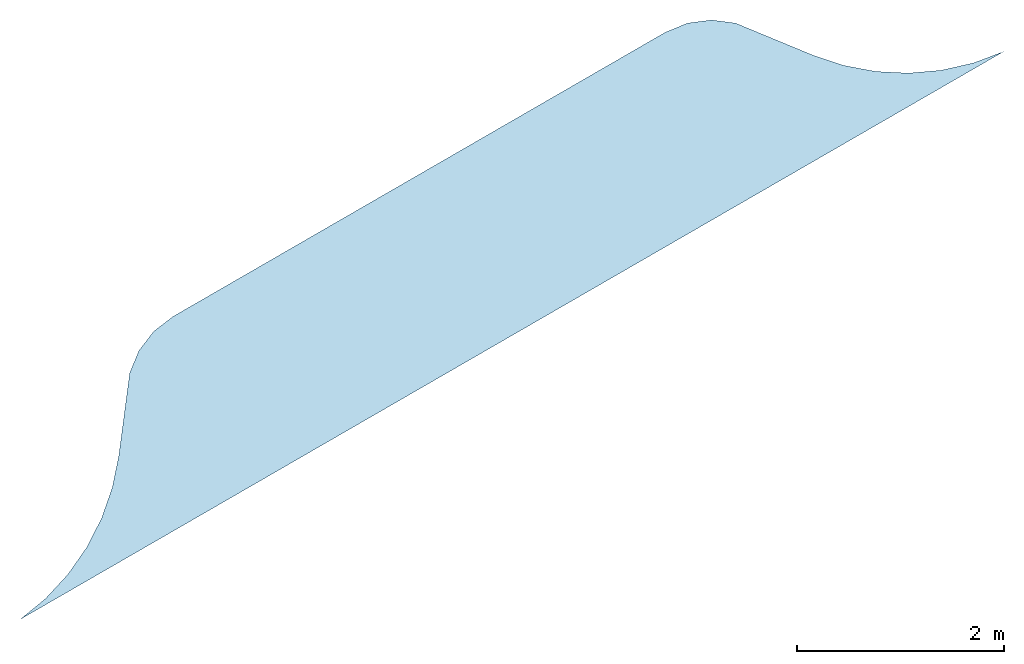
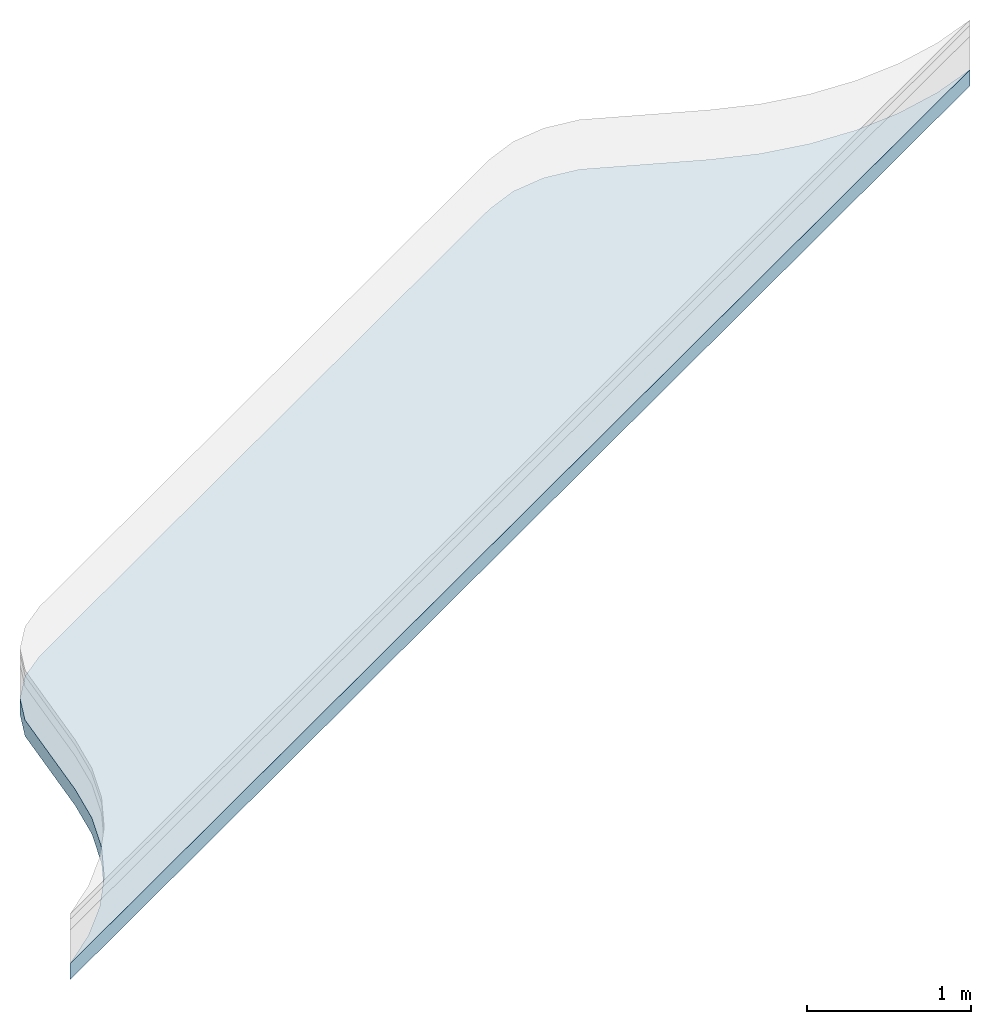
# One storey, part 2 of 2: 1 slab.
"""IFC4 building model written with IfcOpenShell, lengths in millimetres."""

from ifc_helpers import new_model, si_unit, frame, origin_with_axes, place, context, subcontext, project, spatial, triangles, material, type_object, element, save


model = new_model("IFC4")

# Units and contexts
model_context = context("Model", 3, world=origin_with_axes())
body_context = subcontext(model_context, "Body", "Model", "MODEL_VIEW")
ifc_project = project(units=[si_unit("LENGTHUNIT", "METRE", prefix="MILLI"), si_unit("AREAUNIT", "SQUARE_METRE"), si_unit("VOLUMEUNIT", "CUBIC_METRE")], contexts=[model_context])

# Sites, buildings, storey
site_1_placement = place(None, origin_with_axes())
site_1 = spatial("IfcSite", under=ifc_project, at=site_1_placement, CompositionType="COMPLEX")
site_2_placement = place(site_1_placement, frame((1.7108101132749372e-11, 20000.000000000055, 0.0), z_axis=(0.0, 0.0, 1.0), x_axis=(-0.5000000000000002, 0.8660254037844387, 0.0)))
site_2 = spatial("IfcSite", under=site_1, at=site_2_placement, CompositionType="PARTIAL")
building_1_placement = place(site_2_placement, origin_with_axes())
building_1 = spatial("IfcBuilding", under=site_2, at=building_1_placement, Name="road parking - road", CompositionType="COMPLEX")
building_2_placement = place(building_1_placement, origin_with_axes())
building_2 = spatial("IfcBuilding", under=building_1, at=building_2_placement, Name="road parking - road segment", CompositionType="PARTIAL")
storey_placement = place(building_2_placement, origin_with_axes())
storey = spatial("IfcBuildingStorey", under=building_2, at=storey_placement, Name="road - parking", CompositionType="ELEMENT", Elevation=0.0)

# Slab
ifc_material = material(Name="material_stone_generic")
slab_type = type_object("IfcSlabType", Name="road parking - base course", PredefinedType="USERDEFINED")
slab_placement = place(storey_placement, frame((7.507878763135522e-11, 8.05941908765817e-09, -9.023892744153272e-14), z_axis=(-1.97215226305254e-31, -4.7331654313260715e-30, 1.0), x_axis=(1.0, 5.551115123125783e-17, 3.944304526105061e-31)))
element("IfcSlab", 1, at=slab_placement, inside=storey, type_object=slab_type, material=ifc_material, Name="road parking - base course", context=body_context, shape_type="Tessellation", body=[
    triangles([(1800.00000000001, -5500.0000000080745, -369.99999999999335), (1851.8261465675128, 5185.984337374851, -369.9999999999932), (1799.999999999984, 5499.9999999919155, -369.99999999999335), (1851.8261465675178, -5185.984337391003, -369.9999999999932), (1946.0097838825423, 4881.975738320503, -369.9999999999929), (1946.0097838825316, -4881.975738336653, -369.9999999999929), (2080.789545940091, -4593.659589679345, -369.9999999999927), (2080.789545940091, 4593.659589663188, -369.9999999999927), (2253.644862311861, -4326.427807439844, -369.99999999999255), (2253.644862311845, 4326.427807423677, -369.99999999999255), (2461.343096345428, 4085.278000423547, -369.9999999999924), (2461.343096345445, -4085.2780004397127, -369.9999999999924), (2699.999999999995, 3874.7200079965096, -369.99999999999227), (2699.9999999999964, -3874.720008012673, -369.99999999999227), (3336.396103067879, 3386.3961030677847, -369.99999999999227), (3336.396103067876, -3386.3961030839496, -369.99999999999227), (3479.422863405985, -3200.0000000160617, -369.99999999999227), (3479.42286340598, 3199.9999999999027, -369.99999999999227), (3569.333243660163, 2982.937140592177, -369.99999999999227), (3569.333243660172, -2982.93714060834, -369.99999999999227), (3600.0000000000055, 2749.9999999998845, -369.99999999999227), (3600.0000000000186, -2750.000000000098, -369.99999999999227), (1851.8261465675128, 5185.984337374851, -489.9999999997481), (1800.0000000000086, -5500.0000000080745, -489.9999999997481), (1799.999999999984, 5499.9999999919155, -489.9999999997481), (1851.8261465675164, -5185.984337391003, -489.9999999997481), (1946.0097838825423, 4881.975738320503, -489.99999999974744), (1946.0097838825307, -4881.975738336652, -489.99999999974744), (2080.789545940091, -4593.659589679344, -489.99999999974744), (2080.789545940091, 4593.659589663188, -489.99999999974744), (2253.644862311845, 4326.427807423677, -489.99999999974744), (2253.64486231186, -4326.427807439844, -489.99999999974744), (2461.343096345428, 4085.278000423547, -489.99999999974744), (2461.343096345445, -4085.2780004397127, -489.99999999974744), (2699.999999999995, 3874.7200079965096, -489.9999999997467), (2699.9999999999964, -3874.720008012673, -489.9999999997467), (3336.396103067879, 3386.3961030677847, -489.9999999997467), (3336.396103067876, -3386.3961030839496, -489.9999999997467), (3479.4228634059846, -3200.0000000160617, -489.9999999997467), (3479.42286340598, 3199.9999999999027, -489.9999999997467), (3569.333243660163, 2982.937140592177, -489.9999999997467), (3569.3332436601713, -2982.937140608339, -489.9999999997467), (3600.0000000000055, 2749.9999999998845, -489.9999999997467), (3600.0000000000186, -2750.000000000098, -489.9999999997467), (1799.999999999984, 5499.9999999919155, -369.99999999999335), (1800.0000000000086, -5500.0000000080745, -489.9999999997481), (1800.00000000001, -5500.0000000080745, -369.99999999999335), (1799.999999999984, 5499.9999999919155, -489.9999999997481), (1851.8261465675178, -5185.984337391003, -369.9999999999932), (1800.0000000000086, -5500.0000000080745, -489.9999999997481), (1851.8261465675164, -5185.984337391003, -489.9999999997481), (1800.00000000001, -5500.0000000080745, -369.99999999999335), (1946.0097838825307, -4881.975738336652, -489.99999999974744), (1851.8261465675178, -5185.984337391003, -369.9999999999932), (1851.8261465675164, -5185.984337391003, -489.9999999997481), (1946.0097838825316, -4881.975738336653, -369.9999999999929), (2080.789545940091, -4593.659589679345, -369.9999999999927), (1946.0097838825307, -4881.975738336652, -489.99999999974744), (2080.789545940091, -4593.659589679344, -489.99999999974744), (1946.0097838825316, -4881.975738336653, -369.9999999999929), (2253.644862311861, -4326.427807439844, -369.99999999999255), (2080.789545940091, -4593.659589679344, -489.99999999974744), (2253.64486231186, -4326.427807439844, -489.99999999974744), (2080.789545940091, -4593.659589679345, -369.9999999999927), (2461.343096345445, -4085.2780004397127, -369.9999999999924), (2253.64486231186, -4326.427807439844, -489.99999999974744), (2461.343096345445, -4085.2780004397127, -489.99999999974744), (2253.644862311861, -4326.427807439844, -369.99999999999255), (2699.9999999999964, -3874.720008012673, -489.9999999997467), (2461.343096345445, -4085.2780004397127, -369.9999999999924), (2461.343096345445, -4085.2780004397127, -489.99999999974744), (2699.9999999999964, -3874.720008012673, -369.99999999999227), (3336.396103067876, -3386.3961030839496, -369.99999999999227), (2699.9999999999964, -3874.720008012673, -489.9999999997467), (3336.396103067876, -3386.3961030839496, -489.9999999997467), (2699.9999999999964, -3874.720008012673, -369.99999999999227), (3479.422863405985, -3200.0000000160617, -369.99999999999227), (3336.396103067876, -3386.3961030839496, -489.9999999997467), (3479.4228634059846, -3200.0000000160617, -489.9999999997467), (3336.396103067876, -3386.3961030839496, -369.99999999999227), (3569.333243660172, -2982.93714060834, -369.99999999999227), (3479.4228634059846, -3200.0000000160617, -489.9999999997467), (3569.3332436601713, -2982.937140608339, -489.9999999997467), (3479.422863405985, -3200.0000000160617, -369.99999999999227), (3600.0000000000186, -2750.000000000098, -369.99999999999227), (3569.3332436601713, -2982.937140608339, -489.9999999997467), (3600.0000000000186, -2750.000000000098, -489.9999999997467), (3569.333243660172, -2982.93714060834, -369.99999999999227), (3600.0000000000055, 2749.9999999998845, -489.9999999997467), (3600.0000000000186, -2750.000000000098, -369.99999999999227), (3600.0000000000186, -2750.000000000098, -489.9999999997467), (3600.0000000000055, 2749.9999999998845, -369.99999999999227), (3569.333243660163, 2982.937140592177, -369.99999999999227), (3600.0000000000055, 2749.9999999998845, -489.9999999997467), (3569.333243660163, 2982.937140592177, -489.9999999997467), (3600.0000000000055, 2749.9999999998845, -369.99999999999227), (3479.42286340598, 3199.9999999999027, -369.99999999999227), (3569.333243660163, 2982.937140592177, -489.9999999997467), (3479.42286340598, 3199.9999999999027, -489.9999999997467), (3569.333243660163, 2982.937140592177, -369.99999999999227), (3336.396103067879, 3386.3961030677847, -369.99999999999227), (3479.42286340598, 3199.9999999999027, -489.9999999997467), (3336.396103067879, 3386.3961030677847, -489.9999999997467), (3479.42286340598, 3199.9999999999027, -369.99999999999227), (2699.999999999995, 3874.7200079965096, -369.99999999999227), (3336.396103067879, 3386.3961030677847, -489.9999999997467), (2699.999999999995, 3874.7200079965096, -489.9999999997467), (3336.396103067879, 3386.3961030677847, -369.99999999999227), (2461.343096345428, 4085.278000423547, -369.9999999999924), (2699.999999999995, 3874.7200079965096, -489.9999999997467), (2461.343096345428, 4085.278000423547, -489.99999999974744), (2699.999999999995, 3874.7200079965096, -369.99999999999227), (2253.644862311845, 4326.427807423677, -369.99999999999255), (2461.343096345428, 4085.278000423547, -489.99999999974744), (2253.644862311845, 4326.427807423677, -489.99999999974744), (2461.343096345428, 4085.278000423547, -369.9999999999924), (2080.789545940091, 4593.659589663188, -369.9999999999927), (2253.644862311845, 4326.427807423677, -489.99999999974744), (2080.789545940091, 4593.659589663188, -489.99999999974744), (2253.644862311845, 4326.427807423677, -369.99999999999255), (1946.0097838825423, 4881.975738320503, -369.9999999999929), (2080.789545940091, 4593.659589663188, -489.99999999974744), (1946.0097838825423, 4881.975738320503, -489.99999999974744), (2080.789545940091, 4593.659589663188, -369.9999999999927), (1851.8261465675128, 5185.984337374851, -369.9999999999932), (1946.0097838825423, 4881.975738320503, -489.99999999974744), (1851.8261465675128, 5185.984337374851, -489.9999999997481), (1946.0097838825423, 4881.975738320503, -369.9999999999929), (1799.999999999984, 5499.9999999919155, -369.99999999999335), (1851.8261465675128, 5185.984337374851, -489.9999999997481), (1799.999999999984, 5499.9999999919155, -489.9999999997481), (1851.8261465675128, 5185.984337374851, -369.9999999999932)], [[1, 2, 3], [2, 1, 4], [2, 4, 5], [5, 4, 6], [5, 6, 7], [5, 7, 8], [8, 7, 9], [8, 9, 10], [10, 9, 11], [11, 9, 12], [11, 12, 13], [13, 12, 14], [13, 14, 15], [15, 14, 16], [15, 16, 17], [15, 17, 18], [18, 17, 19], [19, 17, 20], [19, 20, 21], [21, 20, 22], [23, 24, 25], [24, 23, 26], [26, 23, 27], [26, 27, 28], [28, 27, 29], [29, 27, 30], [29, 30, 31], [29, 31, 32], [32, 31, 33], [32, 33, 34], [34, 33, 35], [34, 35, 36], [36, 35, 37], [36, 37, 38], [38, 37, 39], [39, 37, 40], [39, 40, 41], [39, 41, 42], [42, 41, 43], [42, 43, 44], [45, 46, 47], [46, 45, 48], [49, 50, 51], [50, 49, 52], [53, 54, 55], [54, 53, 56], [57, 58, 59], [58, 57, 60], [61, 62, 63], [62, 61, 64], [65, 66, 67], [66, 65, 68], [69, 70, 71], [70, 69, 72], [73, 74, 75], [74, 73, 76], [77, 78, 79], [78, 77, 80], [81, 82, 83], [82, 81, 84], [85, 86, 87], [86, 85, 88], [89, 90, 91], [90, 89, 92], [93, 94, 95], [94, 93, 96], [97, 98, 99], [98, 97, 100], [101, 102, 103], [102, 101, 104], [105, 106, 107], [106, 105, 108], [109, 110, 111], [110, 109, 112], [113, 114, 115], [114, 113, 116], [117, 118, 119], [118, 117, 120], [121, 122, 123], [122, 121, 124], [125, 126, 127], [126, 125, 128], [129, 130, 131], [130, 129, 132]]),
])

save(model, "model.ifc")
